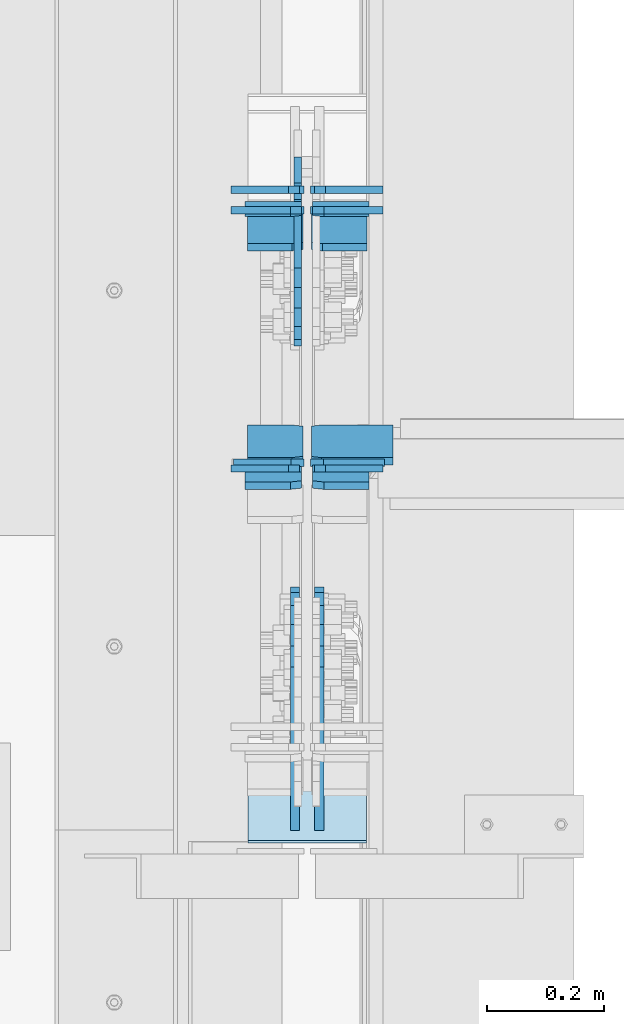
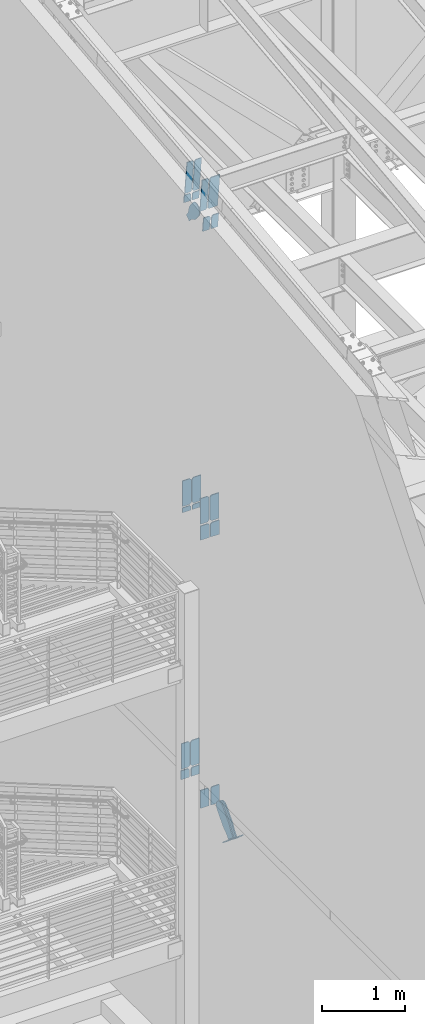
# One storey, part 1024 of 1179: 26 plates, 7 elements without a shape of their own.
"""IFC2X3 building model written with IfcOpenShell, lengths in millimetres."""

from ifc_helpers import new_model, si_unit, frame, origin_with_axes, place, context, subcontext, project, spatial, faceted_brep, material, type_object, element, aggregate, save


model = new_model("IFC2X3")

# Units and contexts
model_context = context("Model", 3, precision=1e-05, world=origin_with_axes())
body_context = subcontext(model_context, "Body", "Model", "MODEL_VIEW")
ifc_project = project(units=[si_unit("LENGTHUNIT", "METRE", prefix="MILLI"), si_unit("AREAUNIT", "SQUARE_METRE"), si_unit("VOLUMEUNIT", "CUBIC_METRE"), si_unit("MASSUNIT", "GRAM", prefix="KILO"), si_unit("TIMEUNIT", "SECOND"), si_unit("PLANEANGLEUNIT", "RADIAN"), si_unit("SOLIDANGLEUNIT", "STERADIAN"), si_unit("THERMODYNAMICTEMPERATUREUNIT", "DEGREE_CELSIUS"), si_unit("LUMINOUSINTENSITYUNIT", "LUMEN")], contexts=[model_context])

# Site, building, storey
site_placement = place(None, origin_with_axes())
site = spatial("IfcSite", under=ifc_project, at=site_placement, CompositionType="ELEMENT")
building_placement = place(site_placement, origin_with_axes())
building = spatial("IfcBuilding", under=site, at=building_placement, Name="Undefined", CompositionType="ELEMENT")
storey_placement = place(building_placement, origin_with_axes())
storey = spatial("IfcBuildingStorey", under=building, at=storey_placement, Name="Undefined", CompositionType="ELEMENT", Elevation=0.0)

# Assembly, plates
assembly_1_placement = place(storey_placement, origin_with_axes())
assembly_1 = element("IfcElementAssembly", 1, at=assembly_1_placement, inside=storey, Name="BEAM", AssemblyPlace="NOTDEFINED", PredefinedType="RIGID_FRAME")
ifc_material_1 = material(Name="STEEL/A36")
plate_type_1 = type_object("IfcPlateType", PredefinedType="NOTDEFINED")
plate_1_placement = place(assembly_1_placement, frame((424.656250000002, 30789.596926768, 12198.8547612233), z_axis=(0.0, -0.112284087038017, 0.993676146336441), x_axis=(-1.0, 0.0, 0.0)))
plate_1 = element("IfcPlate", 2, at=plate_1_placement, type_object=plate_type_1, material=ifc_material_1, Name="PLATE", context=body_context, shape_type="Brep", body=[
    faceted_brep([(0.0, -6.35000000000036, 19.0499999999993), (0.0, -6.350000000195, 479.425000761541), (0.0, 6.34999999980209, 479.425000761548), (0.0, 6.35000000000036, 19.0499999999993), (19.0499992370605, -6.35000000019863, 498.474999998592), (19.0499992370605, 6.34999999979118, 498.474999998596), (95.25, -6.349999999793, 498.474999998598), (95.25, 6.35000000020045, 498.474999998592), (95.25, -6.34999999999309, 1.81898940354586e-12), (95.25, 6.34999999999854, -1.81898940354586e-12), (19.0500000000002, -6.35000000000036, 0.0), (19.0500000000002, 6.35000000000036, 0.0)], [[[0, 1, 2, 3]], [[1, 4, 5, 2]], [[4, 6, 7, 5]], [[6, 8, 9, 7]], [[8, 10, 11, 9]], [[3, 11, 10, 0]], [[5, 7, 9, 11, 3, 2]], [[10, 8, 6, 4, 1, 0]]]),
])
ifc_material_2 = material(Name="STEEL/A572-GR.50")
plate_2_placement = place(assembly_1_placement, frame((534.193750000002, 31156.2703128206, 12240.2883676813), z_axis=(0.0, -0.112284087038017, 0.993676146336441), x_axis=(-1.0, 0.0, 0.0)))
plate_2 = element("IfcPlate", 3, at=plate_2_placement, type_object=plate_type_1, material=ifc_material_2, Name="PLATE", context=body_context, shape_type="Brep", body=[
    faceted_brep([(0.0, -6.34999999999854, 0.0), (0.0, -6.35000000019863, 498.474999998592), (0.0, 6.34999999979118, 498.474999998596), (0.0, 6.34999999999854, 0.0), (76.2000007629395, -6.35000000019863, 498.474999998592), (76.2000007629395, 6.34999999979118, 498.474999998596), (95.25, -6.350000000195, 479.425000761541), (95.25, 6.34999999980209, 479.425000761548), (95.25, -6.35000000000946, 19.0499992370496), (95.25, 6.34999999998399, 19.0499992370533), (76.2000007629395, -6.35000000000218, 0.0), (76.2000007629395, 6.34999999999491, 3.63797880709171e-12)], [[[0, 1, 2, 3]], [[1, 4, 5, 2]], [[4, 6, 7, 5]], [[6, 8, 9, 7]], [[8, 10, 11, 9]], [[10, 0, 3, 11]], [[5, 7, 9, 11, 3, 2]], [[10, 8, 6, 4, 1, 0]]]),
])
plate_3_placement = place(assembly_1_placement, frame((424.656250000002, 31156.2703128206, 12240.2883676813), z_axis=(0.0, -0.112284087038017, 0.993676146336441), x_axis=(-1.0, 0.0, 0.0)))
plate_3 = element("IfcPlate", 4, at=plate_3_placement, type_object=plate_type_1, material=ifc_material_2, Name="PLATE", context=body_context, shape_type="Brep", body=[
    faceted_brep([(0.0, -6.35000000000036, 19.0499999999993), (0.0, -6.350000000195, 479.425000761541), (0.0, 6.34999999980209, 479.425000761548), (0.0, 6.35000000000036, 19.0499999999993), (19.0499992370605, -6.35000000019863, 498.474999998592), (19.0499992370605, 6.34999999979118, 498.474999998596), (95.25, -6.349999999793, 498.474999998598), (95.25, 6.35000000020045, 498.474999998592), (95.25, -6.34999999999309, 1.81898940354586e-12), (95.25, 6.34999999999854, -1.81898940354586e-12), (19.0500000000002, -6.35000000000036, 0.0), (19.0500000000002, 6.35000000000036, 0.0)], [[[0, 1, 2, 3]], [[1, 4, 5, 2]], [[4, 6, 7, 5]], [[6, 8, 9, 7]], [[8, 10, 11, 9]], [[3, 11, 10, 0]], [[5, 7, 9, 11, 3, 2]], [[10, 8, 6, 4, 1, 0]]]),
])
plate_type_2 = type_object("IfcPlateType", PredefinedType="NOTDEFINED")
plate_4_placement = place(assembly_1_placement, frame((438.943750000002, 30733.6261163401, 12694.1774782498), z_axis=(1.0, 0.0, 0.0), x_axis=(0.0, 0.112284087038014, -0.993676146336441)))
plate_4 = element("IfcPlate", 5, at=plate_4_placement, type_object=plate_type_2, material=ifc_material_1, Name="PLATE", context=body_context, shape_type="Brep", body=[
    faceted_brep([(0.0, -6.34999999998763, 17.4624996185248), (0.0, -6.34999999999673, 139.700000000001), (-3.63797880709171e-12, 6.34999999999491, 139.700000000001), (0.0, 6.35000000000582, 17.4624996185175), (498.474999999775, -6.34999999979482, 139.700000000001), (498.474999999769, 6.35000000019681, 139.700000000001), (498.474999999775, -6.34999999979482, 17.4624996185303), (498.474999999769, 6.35000000019681, 17.4624996185303), (481.012500381255, -6.34999999980209, 0.0), (481.01250038125, 6.35000000019136, 0.0), (17.4624996185303, -6.34999999999309, 1.81898940354586e-12), (17.4624996185303, 6.34999999999854, -1.81898940354586e-12)], [[[0, 1, 2, 3]], [[1, 4, 5, 2]], [[4, 6, 7, 5]], [[6, 8, 9, 7]], [[8, 10, 11, 9]], [[10, 0, 3, 11]], [[5, 7, 9, 11, 3, 2]], [[10, 8, 6, 4, 1, 0]]]),
])

# Assembly, plate
assembly_2_placement = place(storey_placement, origin_with_axes())
assembly_2 = element("IfcElementAssembly", 6, at=assembly_2_placement, inside=storey, Name="BEAM", AssemblyPlace="NOTDEFINED", PredefinedType="RIGID_FRAME")
plate_type_3 = type_object("IfcPlateType", PredefinedType="NOTDEFINED")
plate_5_placement = place(assembly_2_placement, frame((426.243750000001, 30730.825, 7615.2375), z_axis=(0.0, 0.0, 1.0), x_axis=(-1.0, 0.0, 0.0)))
plate_5 = element("IfcPlate", 7, at=plate_5_placement, type_object=plate_type_3, material=ifc_material_2, Name="PLATE", context=body_context, shape_type="Brep", body=[
    faceted_brep([(0.0, -6.34999999999854, 22.2250003814697), (0.0, -6.34999999999854, 355.600011825562), (0.0, 6.34999999999854, 355.600011825562), (0.0, 6.34999999999854, 22.2250003814697), (22.2250003814697, -6.34999999999854, 377.825012207031), (22.2250003814697, 6.34999999999854, 377.825012207031), (120.650001525879, -6.34999999999854, 377.825012207031), (120.650001525879, 6.34999999999854, 377.825012207031), (120.650001525879, -6.34999999999854, 0.0), (120.650001525879, 6.34999999999854, 0.0), (22.2250003814697, -6.34999999999854, 0.0), (22.2250003814697, 6.34999999999854, 0.0)], [[[0, 1, 2, 3]], [[1, 4, 5, 2]], [[4, 6, 7, 5]], [[6, 8, 9, 7]], [[8, 10, 11, 9]], [[10, 0, 3, 11]], [[5, 7, 9, 11, 3, 2]], [[10, 8, 6, 4, 1, 0]]]),
])

# Assembly, plates
assembly_3_placement = place(storey_placement, origin_with_axes())
assembly_3 = element("IfcElementAssembly", 8, at=assembly_3_placement, inside=storey, Name="BEAM", AssemblyPlace="NOTDEFINED", PredefinedType="RIGID_FRAME")
plate_6_placement = place(assembly_3_placement, frame((558.006250000002, 31198.4329815544, 3703.6375), z_axis=(0.0, 0.0, 1.0), x_axis=(-1.0, 0.0, 0.0)))
plate_6 = element("IfcPlate", 9, at=plate_6_placement, type_object=plate_type_3, material=ifc_material_2, Name="PLATE", context=body_context, shape_type="Brep", body=[
    faceted_brep([(0.0, -6.34999999999854, 0.0), (0.0, -6.35000000000036, 377.825012207031), (0.0, 6.35000000000036, 377.825012207031), (0.0, 6.34999999999854, 0.0), (98.4250011444092, -6.35000000000036, 377.825012207031), (98.4250011444092, 6.35000000000036, 377.825012207031), (120.650001525879, -6.35000000000036, 355.600011825562), (120.650001525879, 6.35000000000036, 355.600011825562), (120.650001525879, -6.35000000000036, 22.2250003814697), (120.650001525879, 6.35000000000036, 22.2250003814697), (98.4250011444092, -6.35000000000036, 0.0), (98.4250011444092, 6.35000000000036, 0.0)], [[[0, 1, 2, 3]], [[1, 4, 5, 2]], [[4, 6, 7, 5]], [[6, 8, 9, 7]], [[8, 10, 11, 9]], [[10, 0, 3, 11]], [[5, 7, 9, 11, 3, 2]], [[10, 8, 6, 4, 1, 0]]]),
])
plate_7_placement = place(assembly_3_placement, frame((426.243750000002, 31198.4329815544, 3703.6375), z_axis=(0.0, 0.0, 1.0), x_axis=(-1.0, 0.0, 0.0)))
plate_7 = element("IfcPlate", 10, at=plate_7_placement, type_object=plate_type_3, material=ifc_material_2, Name="PLATE", context=body_context, shape_type="Brep", body=[
    faceted_brep([(0.0, -6.34999999999854, 22.2250003814697), (0.0, -6.34999999999854, 355.600011825562), (0.0, 6.34999999999854, 355.600011825562), (0.0, 6.34999999999854, 22.2250003814697), (22.2250003814697, -6.34999999999854, 377.825012207031), (22.2250003814697, 6.34999999999854, 377.825012207031), (120.650001525879, -6.34999999999854, 377.825012207031), (120.650001525879, 6.34999999999854, 377.825012207031), (120.650001525879, -6.34999999999854, 0.0), (120.650001525879, 6.34999999999854, 0.0), (22.2250003814697, -6.34999999999854, 0.0), (22.2250003814697, 6.34999999999854, 0.0)], [[[0, 1, 2, 3]], [[1, 4, 5, 2]], [[4, 6, 7, 5]], [[6, 8, 9, 7]], [[8, 10, 11, 9]], [[10, 0, 3, 11]], [[5, 7, 9, 11, 3, 2]], [[10, 8, 6, 4, 1, 0]]]),
])

# Plate
plate_8_placement = place(assembly_2_placement, frame((422.275, 30721.2999999352, 7594.6), z_axis=(-1.0, 0.0, 0.0), x_axis=(0.0, 0.0, -1.0)))
plate_8 = element("IfcPlate", 11, at=plate_8_placement, type_object=plate_type_3, material=ifc_material_2, Name="PLATE", context=body_context, shape_type="Brep", body=[
    faceted_brep([(0.0, 6.35000000000036, 19.0499999999993), (19.0500000000002, 6.35000000000036, 0.0), (19.0500000000002, -6.35000000000036, 0.0), (0.0, -6.35000000000036, 19.0499999999993), (0.0, -6.34999999999854, 120.650000000001), (0.0, 6.34999999999854, 120.650000000001), (210.124280632681, -6.34999999999854, 120.649999999998), (210.124280632681, 6.34999999999854, 120.649999999998), (210.124280632681, -6.34999999999854, 0.0), (210.124280632681, 6.34999999999854, 0.0)], [[[0, 1, 2, 3]], [[4, 5, 0, 3]], [[4, 6, 7, 5]], [[6, 8, 9, 7]], [[9, 8, 2, 1]], [[5, 7, 9, 1, 0]], [[8, 6, 4, 3, 2]]]),
])

plate_9_placement = place(assembly_2_placement, frame((441.325, 30721.2999999352, 7594.6), z_axis=(1.0, 0.0, 0.0), x_axis=(0.0, 0.0, -1.0)))
plate_9 = element("IfcPlate", 12, at=plate_9_placement, type_object=plate_type_3, material=ifc_material_2, Name="PLATE", context=body_context, shape_type="Brep", body=[
    faceted_brep([(0.0, 6.35000000000036, 19.0499999999993), (19.0500000000002, 6.35000000000036, 0.0), (19.0500000000002, -6.35000000000036, 0.0), (0.0, -6.35000000000036, 19.0499999999993), (0.0, -6.34999999999854, 120.650000000001), (0.0, 6.34999999999854, 120.650000000001), (210.124280632681, -6.34999999999854, 120.649999999998), (210.124280632681, 6.34999999999854, 120.649999999998), (210.124280632681, -6.34999999999854, 0.0), (210.124280632681, 6.34999999999854, 0.0)], [[[0, 1, 2, 3]], [[4, 5, 0, 3]], [[4, 6, 7, 5]], [[6, 8, 9, 7]], [[9, 8, 2, 1]], [[5, 7, 9, 1, 0]], [[8, 6, 4, 3, 2]]]),
])

# Assembly, plate
assembly_4_placement = place(storey_placement, origin_with_axes())
assembly_4 = element("IfcElementAssembly", 13, at=assembly_4_placement, inside=storey, AssemblyPlace="NOTDEFINED", PredefinedType="RIGID_FRAME")
plate_type_4 = type_object("IfcPlateType", PredefinedType="NOTDEFINED")
plate_10_placement = place(assembly_4_placement, frame((415.925000000002, 31210.0093415497, 11898.2274613016), z_axis=(0.0, -0.784152810390105, -0.620567780308727), x_axis=(0.0, 0.620567780308723, -0.784152810390108)))
plate_10 = element("IfcPlate", 14, at=plate_10_placement, type_object=plate_type_4, material=ifc_material_1, context=body_context, shape_type="Brep", body=[
    faceted_brep([(0.0, -6.34999999999854, 0.0), (-101.600000000211, -6.34999999999854, -44.6881937825565), (-101.600000000211, 6.34999999999854, -44.6881937825565), (0.0, 6.34999999999854, 0.0), (-246.684985848258, -6.34999999999854, -44.6881937827675), (-246.684985848258, 6.34999999999854, -44.6881937827675), (-281.313054102191, -6.34999999999854, -37.800242748639), (-281.313054102191, 6.34999999999854, -37.800242748639), (-310.669312868691, -6.34999999999854, -18.1850177516608), (-310.669312868691, 6.34999999999854, -18.1850177516608), (-330.284537865713, -6.34999999999854, 11.1712410148393), (-330.284537865713, 6.34999999999854, 11.1712410148393), (-337.172488899912, -6.34999999999854, 45.7993031647638), (-337.172488899912, 6.34999999999854, 45.7993031647638), (-330.284537865768, -6.34999999999854, 80.4273714187839), (-330.284537865768, 6.34999999999854, 80.4273714187839), (-310.669312868773, -6.34999999999854, 109.783630185371), (-310.669312868773, 6.34999999999854, 109.783630185371), (-281.313054102271, -6.34999999999854, 129.398855182466), (-281.313054102271, 6.34999999999854, 129.398855182466), (-246.684988899762, -6.34999999999854, 136.286806216707), (-246.684988899762, 6.34999999999854, 136.286806216707), (-101.600000000377, -6.34999999999854, 136.286806216911), (-101.600000000377, 6.34999999999854, 136.286806216911), (-8.18545231595635e-11, -6.34999999999854, 91.5986124346418), (-8.18545231595635e-11, 6.34999999999854, 91.5986124346418), (71.7550000025622, -6.35000000000002, 91.5986124349001), (71.7550000025622, 6.35000000000002, 91.5986124349001), (71.7550000025931, -6.35000000000002, 1.09139364212751e-10), (71.7550000025931, 6.35000000000002, 1.09139364212751e-10)], [[[0, 1, 2, 3]], [[1, 4, 5, 2]], [[4, 6, 7, 5]], [[6, 8, 9, 7]], [[8, 10, 11, 9]], [[10, 12, 13, 11]], [[12, 14, 15, 13]], [[14, 16, 17, 15]], [[16, 18, 19, 17]], [[18, 20, 21, 19]], [[20, 22, 23, 21]], [[22, 24, 25, 23]], [[24, 26, 27, 25]], [[26, 28, 29, 27]], [[28, 0, 3, 29]], [[5, 7, 9, 11, 13, 15, 17, 19, 21, 23, 25, 27, 29, 3, 2]], [[28, 26, 24, 22, 20, 18, 16, 14, 12, 10, 8, 6, 4, 1, 0]]]),
])
aggregate(assembly_4, [plate_10])

assembly_5_placement = place(storey_placement, origin_with_axes())
assembly_5 = element("IfcElementAssembly", 15, at=assembly_5_placement, inside=storey, Name="Plate", AssemblyPlace="NOTDEFINED", PredefinedType="RIGID_FRAME")
plate_type_5 = type_object("IfcPlateType", PredefinedType="NOTDEFINED")
plate_11_placement = place(assembly_5_placement, frame((533.400000000002, 30233.8634093408, 3194.42286769792), z_axis=(0.0, -0.74575357167811, 0.666221892712438), x_axis=(-1.0, 0.0, 0.0)))
plate_11 = element("IfcPlate", 16, at=plate_11_placement, type_object=plate_type_5, material=ifc_material_1, Name="Plate", context=body_context, shape_type="Brep", body=[
    faceted_brep([(0.0, -3.17500000000109, 0.0), (0.0, -3.17500000000291, 203.200000000368), (0.0, 3.17499999998836, 203.200000000361), (0.0, 3.17500000000109, 7.27595761418343e-12), (203.199999999997, -3.17500000000291, 203.200000000368), (203.199999999997, 3.17499999998836, 203.200000000361), (203.199999999997, -3.17499999999927, 3.63797880709171e-12), (203.199999999997, 3.17499999999382, -3.63797880709171e-12)], [[[0, 1, 2, 3]], [[1, 4, 5, 2]], [[4, 6, 7, 5]], [[6, 0, 3, 7]], [[5, 7, 3, 2]], [[6, 4, 1, 0]]]),
])
aggregate(assembly_5, [plate_11])

# Plate
plate_type_6 = type_object("IfcPlateType", PredefinedType="NOTDEFINED")
plate_12_placement = place(assembly_1_placement, frame((422.275000000001, 31158.7993974739, 12215.0125034411), z_axis=(-1.0, 0.0, 0.0), x_axis=(0.0, 0.112284087038014, -0.993676146336441)))
plate_12 = element("IfcPlate", 17, at=plate_12_placement, type_object=plate_type_6, material=ifc_material_2, Name="PLATE", context=body_context, shape_type="Brep", body=[
    faceted_brep([(0.0, 6.35000000000036, 19.0499999999993), (19.0500000000002, 6.35000000000036, 0.0), (19.0500000000002, -6.35000000000036, 0.0), (0.0, -6.35000000000036, 19.0499999999993), (0.0, -6.35000000000036, 96.8374999999978), (0.0, 6.35000000000036, 96.8374999999978), (118.342741124317, -6.34999999994398, 96.8375), (118.342741124314, 6.3500000000422, 96.8375), (118.342741124317, -6.34999999994398, 0.0), (118.342741124314, 6.3500000000422, 0.0)], [[[0, 1, 2, 3]], [[4, 5, 0, 3]], [[4, 6, 7, 5]], [[6, 8, 9, 7]], [[9, 8, 2, 1]], [[5, 7, 9, 1, 0]], [[8, 6, 4, 3, 2]]]),
])

plate_13_placement = place(assembly_1_placement, frame((441.325000000001, 31158.7993974739, 12215.0125034411), z_axis=(1.0, 0.0, 0.0), x_axis=(0.0, 0.112284087038014, -0.993676146336441)))
plate_13 = element("IfcPlate", 18, at=plate_13_placement, type_object=plate_type_6, material=ifc_material_2, Name="PLATE", context=body_context, shape_type="Brep", body=[
    faceted_brep([(0.0, 6.35000000000036, 19.0499999999993), (19.0500000000002, 6.35000000000036, 0.0), (19.0500000000002, -6.35000000000036, 0.0), (0.0, -6.35000000000036, 19.0499999999993), (0.0, -6.35000000000036, 96.8374999999978), (0.0, 6.35000000000036, 96.8374999999978), (118.342741124317, -6.34999999994398, 96.8375), (118.342741124314, 6.3500000000422, 96.8375), (118.342741124317, -6.34999999994398, 0.0), (118.342741124314, 6.3500000000422, 0.0)], [[[0, 1, 2, 3]], [[4, 5, 0, 3]], [[4, 6, 7, 5]], [[6, 8, 9, 7]], [[9, 8, 2, 1]], [[5, 7, 9, 1, 0]], [[8, 6, 4, 3, 2]]]),
])

plate_14_placement = place(assembly_1_placement, frame((422.275000000001, 30691.8705472869, 12162.2501624541), z_axis=(-1.0, 0.0, 0.0), x_axis=(0.0, 0.112284087038014, -0.993676146336441)))
plate_14 = element("IfcPlate", 19, at=plate_14_placement, type_object=plate_type_6, material=ifc_material_2, Name="PLATE", context=body_context, shape_type="Brep", body=[
    faceted_brep([(0.0, 6.35000000000036, 19.0499999999993), (19.0500000000002, 6.35000000000036, 0.0), (19.0500000000002, -6.35000000000036, 0.0), (0.0, -6.35000000000036, 19.0499999999993), (0.0, -6.35000000000036, 96.8374999999978), (0.0, 6.35000000000036, 96.8374999999978), (215.455080662674, -6.3499999999076, 96.8375000000015), (215.45508066267, 6.35000000008222, 96.8375000000015), (215.455080662674, -6.3499999999076, 0.0), (215.45508066267, 6.35000000008222, 0.0)], [[[0, 1, 2, 3]], [[4, 5, 0, 3]], [[4, 6, 7, 5]], [[6, 8, 9, 7]], [[9, 8, 2, 1]], [[5, 7, 9, 1, 0]], [[8, 6, 4, 3, 2]]]),
])

plate_15_placement = place(assembly_1_placement, frame((441.325000000001, 30691.8705472869, 12162.2501624541), z_axis=(1.0, 0.0, 0.0), x_axis=(0.0, 0.112284087038014, -0.993676146336441)))
plate_15 = element("IfcPlate", 20, at=plate_15_placement, type_object=plate_type_6, material=ifc_material_2, Name="PLATE", context=body_context, shape_type="Brep", body=[
    faceted_brep([(0.0, 6.35000000000036, 19.0499999999993), (19.0500000000002, 6.35000000000036, 0.0), (19.0500000000002, -6.35000000000036, 0.0), (0.0, -6.35000000000036, 19.0499999999993), (0.0, -6.35000000000036, 96.8374999999978), (0.0, 6.35000000000036, 96.8374999999978), (215.455080662674, -6.3499999999076, 96.8375000000015), (215.45508066267, 6.35000000008222, 96.8375000000015), (215.455080662674, -6.3499999999076, 0.0), (215.45508066267, 6.35000000008222, 0.0)], [[[0, 1, 2, 3]], [[4, 5, 0, 3]], [[4, 6, 7, 5]], [[6, 8, 9, 7]], [[9, 8, 2, 1]], [[5, 7, 9, 1, 0]], [[8, 6, 4, 3, 2]]]),
])

aggregate(assembly_1, [plate_1, plate_4, plate_2, plate_3, plate_12, plate_13, plate_14, plate_15])

plate_type_7 = type_object("IfcPlateType", PredefinedType="NOTDEFINED")
plate_16_placement = place(assembly_2_placement, frame((437.356250000001, 30730.825, 7615.2375), z_axis=(0.0, 0.0, 1.0), x_axis=(1.0, 0.0, 0.0)))
plate_16 = element("IfcPlate", 21, at=plate_16_placement, type_object=plate_type_7, material=ifc_material_2, Name="PLATE", context=body_context, shape_type="Brep", body=[
    faceted_brep([(0.0, -6.34999999999854, 22.2250003814697), (0.0, -6.34999999999854, 355.600011825562), (0.0, 6.34999999999854, 355.600011825562), (0.0, 6.34999999999854, 22.2250003814697), (22.2250003814697, -6.34999999999854, 377.825012207031), (22.2250003814697, 6.34999999999854, 377.825012207031), (127.000004873051, -6.34999999999854, 377.825), (127.000004873051, 6.34999999999854, 377.825), (127.000004873051, -6.34999999999854, 0.0), (127.000004873051, 6.34999999999854, 0.0), (22.2250003814697, -6.34999999999854, 0.0), (22.2250003814697, 6.34999999999854, 0.0)], [[[0, 1, 2, 3]], [[1, 4, 5, 2]], [[4, 6, 7, 5]], [[6, 8, 9, 7]], [[8, 10, 11, 9]], [[10, 0, 3, 11]], [[5, 7, 9, 11, 3, 2]], [[10, 8, 6, 4, 1, 0]]]),
])

plate_type_8 = type_object("IfcPlateType", PredefinedType="NOTDEFINED")
plate_17_placement = place(assembly_2_placement, frame((422.275, 31163.6495595079, 7594.6), z_axis=(-1.0, 0.0, 0.0), x_axis=(0.0, 0.0, -1.0)))
plate_17 = element("IfcPlate", 22, at=plate_17_placement, type_object=plate_type_8, material=ifc_material_2, Name="PLATE", context=body_context, shape_type="Brep", body=[
    faceted_brep([(0.0, 6.35000000000036, 19.0499999999993), (19.0500000000002, 6.35000000000036, 0.0), (19.0500000000002, -6.35000000000036, 0.0), (0.0, -6.35000000000036, 19.0499999999993), (0.0, -6.34999999999854, 120.650000000001), (0.0, 6.34999999999854, 120.650000000001), (72.5857973213488, -6.34999999999854, 120.65), (72.5857973213488, 6.34999999999854, 120.65), (72.5857973213488, -6.34999999999854, 0.0), (72.5857973213488, 6.34999999999854, 0.0)], [[[0, 1, 2, 3]], [[4, 5, 0, 3]], [[4, 6, 7, 5]], [[6, 8, 9, 7]], [[9, 8, 2, 1]], [[5, 7, 9, 1, 0]], [[8, 6, 4, 3, 2]]]),
])

plate_18_placement = place(assembly_2_placement, frame((441.325, 31163.6495595079, 7594.6), z_axis=(1.0, 0.0, 0.0), x_axis=(0.0, 0.0, -1.0)))
plate_18 = element("IfcPlate", 23, at=plate_18_placement, type_object=plate_type_8, material=ifc_material_2, Name="PLATE", context=body_context, shape_type="Brep", body=[
    faceted_brep([(0.0, 6.35000000000036, 19.0499999999993), (19.0500000000002, 6.35000000000036, 0.0), (19.0500000000002, -6.35000000000036, 0.0), (0.0, -6.35000000000036, 19.0499999999993), (0.0, -6.34999999999854, 120.650000000001), (0.0, 6.34999999999854, 120.650000000001), (72.5857973213488, -6.34999999999854, 120.65), (72.5857973213488, 6.34999999999854, 120.65), (72.5857973213488, -6.34999999999854, 0.0), (72.5857973213488, 6.34999999999854, 0.0)], [[[0, 1, 2, 3]], [[4, 5, 0, 3]], [[4, 6, 7, 5]], [[6, 8, 9, 7]], [[9, 8, 2, 1]], [[5, 7, 9, 1, 0]], [[8, 6, 4, 3, 2]]]),
])

plate_type_9 = type_object("IfcPlateType", PredefinedType="NOTDEFINED")
plate_19_placement = place(assembly_2_placement, frame((426.243750000001, 31163.6495595079, 7615.2375), z_axis=(-1.0, 0.0, 0.0), x_axis=(0.0, 0.0, 1.0)))
plate_19 = element("IfcPlate", 24, at=plate_19_placement, type_object=plate_type_9, material=ifc_material_2, Name="PLATE", context=body_context, shape_type="Brep", body=[
    faceted_brep([(0.0, -6.34999999999854, 22.2250003814697), (0.0, -6.34999999999854, 124.618750000001), (0.0, 6.34999999999854, 124.618750000001), (0.0, 6.34999999999854, 22.2250003814697), (377.825000000001, -6.34999999999854, 124.61875), (377.825000000001, 6.34999999999854, 124.61875), (377.825000000001, -6.34999999999854, 22.2250003814697), (377.825000000001, 6.34999999999854, 22.2250003814697), (355.599999618531, -6.34999999999854, 0.0), (355.599999618531, 6.34999999999854, 0.0), (22.2250003814697, -6.34999999999854, 0.0), (22.2250003814697, 6.34999999999854, 0.0)], [[[0, 1, 2, 3]], [[1, 4, 5, 2]], [[4, 6, 7, 5]], [[6, 8, 9, 7]], [[8, 10, 11, 9]], [[10, 0, 3, 11]], [[5, 7, 9, 11, 3, 2]], [[10, 8, 6, 4, 1, 0]]]),
])

plate_20_placement = place(assembly_2_placement, frame((437.356250000001, 31163.6495595079, 7615.2375), z_axis=(1.0, 0.0, 0.0), x_axis=(0.0, 0.0, 1.0)))
plate_20 = element("IfcPlate", 25, at=plate_20_placement, type_object=plate_type_9, material=ifc_material_2, Name="PLATE", context=body_context, shape_type="Brep", body=[
    faceted_brep([(0.0, -6.34999999999854, 22.2250003814697), (0.0, -6.34999999999854, 124.618750000001), (0.0, 6.34999999999854, 124.618750000001), (0.0, 6.34999999999854, 22.2250003814697), (377.825000000001, -6.34999999999854, 124.61875), (377.825000000001, 6.34999999999854, 124.61875), (377.825000000001, -6.34999999999854, 22.2250003814697), (377.825000000001, 6.34999999999854, 22.2250003814697), (355.599999618531, -6.34999999999854, 0.0), (355.599999618531, 6.34999999999854, 0.0), (22.2250003814697, -6.34999999999854, 0.0), (22.2250003814697, 6.34999999999854, 0.0)], [[[0, 1, 2, 3]], [[1, 4, 5, 2]], [[4, 6, 7, 5]], [[6, 8, 9, 7]], [[8, 10, 11, 9]], [[10, 0, 3, 11]], [[5, 7, 9, 11, 3, 2]], [[10, 8, 6, 4, 1, 0]]]),
])

aggregate(assembly_2, [plate_5, plate_16, plate_17, plate_18, plate_19, plate_20, plate_8, plate_9])

plate_type_10 = type_object("IfcPlateType", PredefinedType="NOTDEFINED")
plate_21_placement = place(assembly_3_placement, frame((419.100000000001, 31198.453019409, 3683.00000010165), z_axis=(-1.0, 0.0, 0.0), x_axis=(0.0, 0.0, -1.0)))
plate_21 = element("IfcPlate", 26, at=plate_21_placement, type_object=plate_type_10, material=ifc_material_2, Name="PLATE", context=body_context, shape_type="Brep", body=[
    faceted_brep([(0.0, -6.35000000000036, 19.0499999999993), (0.0, -6.35000000000036, 117.474999999999), (0.0, 6.35000000000036, 117.474999999999), (0.0, 6.35000000000036, 19.0499999999993), (131.240777340528, -6.34999999982756, 117.475), (131.240777340528, 6.35000000017317, 117.475), (131.240777340528, -6.34999999982756, 0.0), (131.240777340528, 6.35000000017317, 0.0), (19.0500000000002, -6.35000000000036, 0.0), (19.0500000000002, 6.35000000000036, 0.0)], [[[0, 1, 2, 3]], [[1, 4, 5, 2]], [[4, 6, 7, 5]], [[6, 8, 9, 7]], [[3, 9, 8, 0]], [[5, 7, 9, 3, 2]], [[8, 6, 4, 1, 0]]]),
])

plate_22_placement = place(assembly_3_placement, frame((444.500000000001, 31198.453019409, 3683.00000010165), z_axis=(1.0, 0.0, 0.0), x_axis=(0.0, 0.0, -1.0)))
plate_22 = element("IfcPlate", 27, at=plate_22_placement, type_object=plate_type_10, material=ifc_material_2, Name="PLATE", context=body_context, shape_type="Brep", body=[
    faceted_brep([(0.0, -6.35000000000036, 19.0499999999993), (0.0, -6.35000000000036, 117.474999999999), (0.0, 6.35000000000036, 117.474999999999), (0.0, 6.35000000000036, 19.0499999999993), (131.240777340528, -6.34999999982756, 117.475), (131.240777340528, 6.35000000017317, 117.475), (131.240777340528, -6.34999999982756, 0.0), (131.240777340528, 6.35000000017317, 0.0), (19.0500000000002, -6.35000000000036, 0.0), (19.0500000000002, 6.35000000000036, 0.0)], [[[0, 1, 2, 3]], [[1, 4, 5, 2]], [[4, 6, 7, 5]], [[6, 8, 9, 7]], [[3, 9, 8, 0]], [[5, 7, 9, 3, 2]], [[8, 6, 4, 1, 0]]]),
])

plate_23_placement = place(assembly_3_placement, frame((419.100000000001, 30721.3000004082, 3683.0), z_axis=(-1.0, 0.0, 0.0), x_axis=(0.0, 0.0, -1.0)))
plate_23 = element("IfcPlate", 28, at=plate_23_placement, type_object=plate_type_10, material=ifc_material_2, Name="PLATE", context=body_context, shape_type="Brep", body=[
    faceted_brep([(0.0, -6.35000000000036, 19.0499999999993), (0.0, -6.35000000000036, 117.474999999999), (0.0, 6.35000000000036, 117.474999999999), (0.0, 6.35000000000036, 19.0499999999993), (266.600120794104, -6.34999999976208, 117.475), (266.600120794105, 6.35000000023501, 117.475), (266.600120794104, -6.34999999976208, 0.0), (266.600120794105, 6.35000000023501, 0.0), (19.0500000000002, -6.35000000000036, 0.0), (19.0500000000002, 6.35000000000036, 0.0)], [[[0, 1, 2, 3]], [[1, 4, 5, 2]], [[4, 6, 7, 5]], [[6, 8, 9, 7]], [[3, 9, 8, 0]], [[5, 7, 9, 3, 2]], [[8, 6, 4, 1, 0]]]),
])

plate_24_placement = place(assembly_3_placement, frame((444.500000000001, 30721.3000004082, 3683.0), z_axis=(1.0, 0.0, 0.0), x_axis=(0.0, 0.0, -1.0)))
plate_24 = element("IfcPlate", 29, at=plate_24_placement, type_object=plate_type_10, material=ifc_material_2, Name="PLATE", context=body_context, shape_type="Brep", body=[
    faceted_brep([(0.0, -6.35000000000036, 19.0499999999993), (0.0, -6.35000000000036, 117.474999999999), (0.0, 6.35000000000036, 117.474999999999), (0.0, 6.35000000000036, 19.0499999999993), (266.600120794104, -6.34999999976208, 117.475), (266.600120794105, 6.35000000023501, 117.475), (266.600120794104, -6.34999999976208, 0.0), (266.600120794105, 6.35000000023501, 0.0), (19.0500000000002, -6.35000000000036, 0.0), (19.0500000000002, 6.35000000000036, 0.0)], [[[0, 1, 2, 3]], [[1, 4, 5, 2]], [[4, 6, 7, 5]], [[6, 8, 9, 7]], [[3, 9, 8, 0]], [[5, 7, 9, 3, 2]], [[8, 6, 4, 1, 0]]]),
])

aggregate(assembly_3, [plate_21, plate_22, plate_6, plate_7, plate_23, plate_24])

# Assembly, plate
assembly_6_placement = place(storey_placement, origin_with_axes())
assembly_6 = element("IfcElementAssembly", 30, at=assembly_6_placement, inside=storey, AssemblyPlace="NOTDEFINED", PredefinedType="RIGID_FRAME")
plate_type_11 = type_object("IfcPlateType", PredefinedType="NOTDEFINED")
plate_25_placement = place(assembly_6_placement, frame((411.162500000002, 30210.7569966276, 3210.80763402645), z_axis=(0.0, -0.74575357167811, 0.666221892712438), x_axis=(0.0, 0.666221892712437, 0.74575357167811)))
plate_25 = element("IfcPlate", 31, at=plate_25_placement, type_object=plate_type_11, material=ifc_material_1, context=body_context, shape_type="Brep", body=[
    faceted_brep([(0.0, -7.9375, 0.0), (-8.00355337560177e-11, -7.9375, 146.904840309817), (-8.00355337560177e-11, 7.9375, 146.904840309817), (0.0, 7.9375, 0.0), (80.0100000003295, -7.9375, 146.904840309766), (80.0100000003295, 7.9375, 146.904840309766), (181.610000002391, -7.9375, 168.702420152473), (181.610000002391, 7.9375, 168.702420152473), (400.931138856435, -7.9375, 168.702420152254), (400.931138856435, 7.9375, 168.702420152254), (437.38173578924, -7.9375, 161.451945623954), (437.38173578924, 7.9375, 161.451945623954), (468.283059764515, -7.9375, 140.804341060335), (468.283059764515, 7.9375, 140.804341060335), (488.930664328229, -7.9375, 109.903017085206), (488.930664328229, 7.9375, 109.903017085206), (496.181138856569, -7.9375, 73.4524201550594), (496.181138856569, 7.9375, 73.4524201550594), (488.930664328283, -7.9375, 37.0018232223192), (488.930664328283, 7.9375, 37.0018232223192), (468.283059764544, -7.9375, 6.10049924711348), (468.283059764544, 7.9375, 6.10049924711348), (437.381735789197, -7.9375, -14.5471053165384), (437.381735789197, 7.9375, -14.5471053165384), (400.931138855318, -7.9375, -21.7975798447951), (400.931138855318, 7.9375, -21.7975798447951), (181.610000002645, -7.9375, -21.7975798445696), (181.610000002645, 7.9375, -21.7975798445696), (80.0100000004022, -7.9375, -5.82076609134674e-11), (80.0100000004022, 7.9375, -5.82076609134674e-11)], [[[0, 1, 2, 3]], [[1, 4, 5, 2]], [[4, 6, 7, 5]], [[6, 8, 9, 7]], [[8, 10, 11, 9]], [[10, 12, 13, 11]], [[12, 14, 15, 13]], [[14, 16, 17, 15]], [[16, 18, 19, 17]], [[18, 20, 21, 19]], [[20, 22, 23, 21]], [[22, 24, 25, 23]], [[24, 26, 27, 25]], [[26, 28, 29, 27]], [[28, 0, 3, 29]], [[5, 7, 9, 11, 13, 15, 17, 19, 21, 23, 25, 27, 29, 3, 2]], [[28, 26, 24, 22, 20, 18, 16, 14, 12, 10, 8, 6, 4, 1, 0]]]),
])
aggregate(assembly_6, [plate_25])

assembly_7_placement = place(storey_placement, origin_with_axes())
assembly_7 = element("IfcElementAssembly", 32, at=assembly_7_placement, inside=storey, AssemblyPlace="NOTDEFINED", PredefinedType="RIGID_FRAME")
plate_26_placement = place(assembly_7_placement, frame((452.437500000002, 30210.7569966276, 3210.80763402645), z_axis=(0.0, -0.74575357167811, 0.666221892712438), x_axis=(0.0, 0.666221892712437, 0.74575357167811)))
plate_26 = element("IfcPlate", 33, at=plate_26_placement, type_object=plate_type_11, material=ifc_material_1, context=body_context, shape_type="Brep", body=[
    faceted_brep([(0.0, -7.9375, 0.0), (-8.00355337560177e-11, -7.9375, 146.904840309817), (-8.00355337560177e-11, 7.9375, 146.904840309817), (0.0, 7.9375, 0.0), (80.0100000003295, -7.9375, 146.904840309766), (80.0100000003295, 7.9375, 146.904840309766), (181.610000002391, -7.9375, 168.702420152473), (181.610000002391, 7.9375, 168.702420152473), (400.931138856435, -7.9375, 168.702420152254), (400.931138856435, 7.9375, 168.702420152254), (437.38173578924, -7.9375, 161.451945623954), (437.38173578924, 7.9375, 161.451945623954), (468.283059764515, -7.9375, 140.804341060335), (468.283059764515, 7.9375, 140.804341060335), (488.930664328229, -7.9375, 109.903017085206), (488.930664328229, 7.9375, 109.903017085206), (496.181138856569, -7.9375, 73.4524201550594), (496.181138856569, 7.9375, 73.4524201550594), (488.930664328283, -7.9375, 37.0018232223192), (488.930664328283, 7.9375, 37.0018232223192), (468.283059764544, -7.9375, 6.10049924711348), (468.283059764544, 7.9375, 6.10049924711348), (437.381735789197, -7.9375, -14.5471053165384), (437.381735789197, 7.9375, -14.5471053165384), (400.931138855318, -7.9375, -21.7975798447951), (400.931138855318, 7.9375, -21.7975798447951), (181.610000002645, -7.9375, -21.7975798445696), (181.610000002645, 7.9375, -21.7975798445696), (80.0100000004022, -7.9375, -5.82076609134674e-11), (80.0100000004022, 7.9375, -5.82076609134674e-11)], [[[0, 1, 2, 3]], [[1, 4, 5, 2]], [[4, 6, 7, 5]], [[6, 8, 9, 7]], [[8, 10, 11, 9]], [[10, 12, 13, 11]], [[12, 14, 15, 13]], [[14, 16, 17, 15]], [[16, 18, 19, 17]], [[18, 20, 21, 19]], [[20, 22, 23, 21]], [[22, 24, 25, 23]], [[24, 26, 27, 25]], [[26, 28, 29, 27]], [[28, 0, 3, 29]], [[5, 7, 9, 11, 13, 15, 17, 19, 21, 23, 25, 27, 29, 3, 2]], [[28, 26, 24, 22, 20, 18, 16, 14, 12, 10, 8, 6, 4, 1, 0]]]),
])
aggregate(assembly_7, [plate_26])

save(model, "model.ifc")
